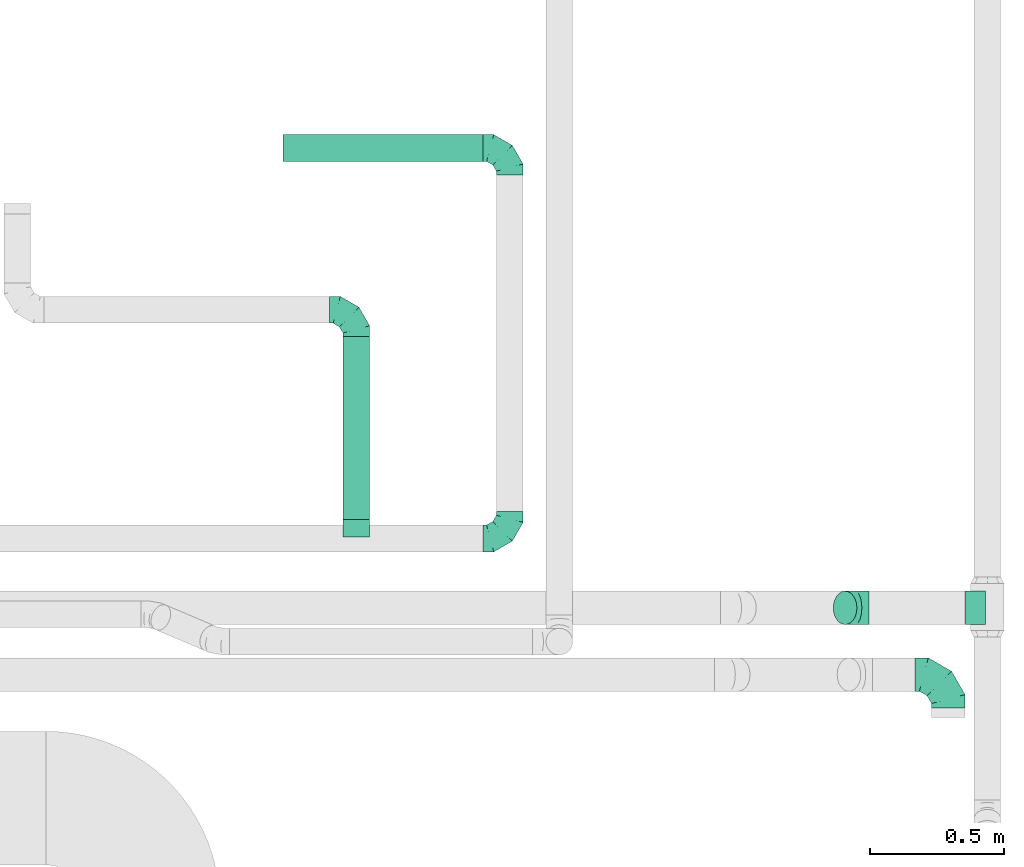
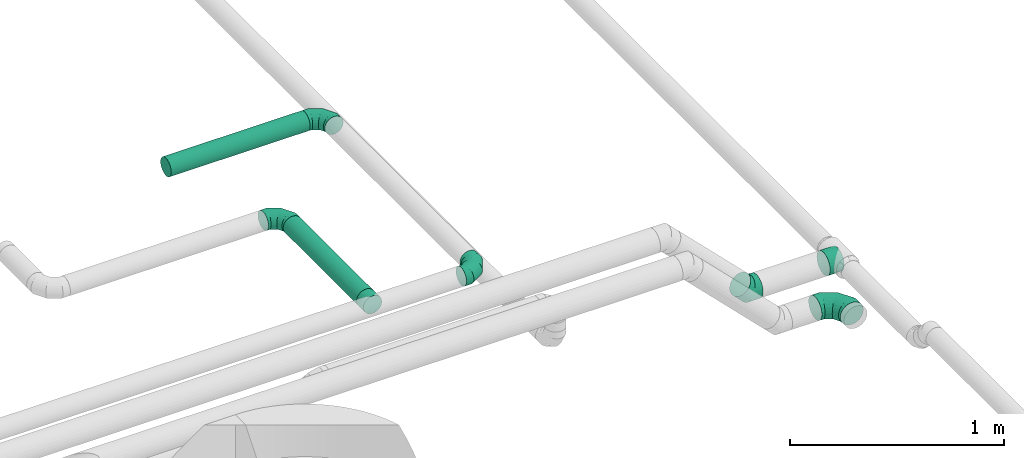
# One storey, part 51 of 60: 7 flow fittings, 2 flow segments.
"""IFC2X3 building model written with IfcOpenShell, lengths in millimetres."""

from ifc_helpers import new_model, entity, si_unit, converted_unit, derived_unit, direction, frame, origin, origin_2d_with_axis, place, context, subcontext, project, spatial, circle, extrude, faceted_brep, source, transform, mapped, material, type_object, type_shapes, element, save


model = new_model("IFC2X3")

# Units and contexts
model_context = context("Model", 3, precision=0.01, world=origin(), true_north=direction((6.12303176911189e-17, 1.0)))
body_context = subcontext(model_context, "Body", "Model", "MODEL_VIEW")
ifc_project = project(units=[si_unit("LENGTHUNIT", "METRE", prefix="MILLI"), si_unit("AREAUNIT", "SQUARE_METRE"), si_unit("VOLUMEUNIT", "CUBIC_METRE"), converted_unit("PLANEANGLEUNIT", "DEGREE", entity("IfcRatioMeasure", 0.0174532925199433), si_unit("PLANEANGLEUNIT", "RADIAN"), dimensions=[0, 0, 0, 0, 0, 0, 0]), si_unit("MASSUNIT", "GRAM", prefix="KILO"), derived_unit("MASSDENSITYUNIT", [(si_unit("MASSUNIT", "GRAM", prefix="KILO"), 1), (si_unit("LENGTHUNIT", "METRE"), -3)]), derived_unit("MOMENTOFINERTIAUNIT", [(si_unit("LENGTHUNIT", "METRE"), 4)]), si_unit("TIMEUNIT", "SECOND"), si_unit("FREQUENCYUNIT", "HERTZ"), si_unit("THERMODYNAMICTEMPERATUREUNIT", "DEGREE_CELSIUS"), derived_unit("THERMALTRANSMITTANCEUNIT", [(si_unit("MASSUNIT", "GRAM", prefix="KILO"), 1), (si_unit("THERMODYNAMICTEMPERATUREUNIT", "KELVIN"), -1), (si_unit("TIMEUNIT", "SECOND"), -3)]), derived_unit("VOLUMETRICFLOWRATEUNIT", [(si_unit("LENGTHUNIT", "METRE"), 3), (si_unit("TIMEUNIT", "SECOND"), -1)]), derived_unit("MASSFLOWRATEUNIT", [(si_unit("MASSUNIT", "GRAM", prefix="KILO"), 1), (si_unit("TIMEUNIT", "SECOND"), -1)]), derived_unit("ROTATIONALFREQUENCYUNIT", [(si_unit("TIMEUNIT", "SECOND"), -1)]), si_unit("ELECTRICCURRENTUNIT", "AMPERE"), si_unit("ELECTRICVOLTAGEUNIT", "VOLT"), si_unit("POWERUNIT", "WATT"), si_unit("FORCEUNIT", "NEWTON", prefix="KILO"), si_unit("ILLUMINANCEUNIT", "LUX"), si_unit("LUMINOUSFLUXUNIT", "LUMEN"), si_unit("LUMINOUSINTENSITYUNIT", "CANDELA"), derived_unit("USERDEFINED", [(si_unit("MASSUNIT", "GRAM", prefix="KILO"), -1), (si_unit("LENGTHUNIT", "METRE"), -2), (si_unit("TIMEUNIT", "SECOND"), 3), (si_unit("LUMINOUSFLUXUNIT", "LUMEN"), 1)]), derived_unit("LINEARVELOCITYUNIT", [(si_unit("LENGTHUNIT", "METRE"), 1), (si_unit("TIMEUNIT", "SECOND"), -1)]), si_unit("PRESSUREUNIT", "PASCAL"), derived_unit("USERDEFINED", [(si_unit("LENGTHUNIT", "METRE"), -2), (si_unit("MASSUNIT", "GRAM", prefix="KILO"), 1), (si_unit("TIMEUNIT", "SECOND"), -2)]), derived_unit("LINEARFORCEUNIT", [(si_unit("MASSUNIT", "GRAM", prefix="KILO"), 1), (si_unit("LENGTHUNIT", "METRE"), 1), (si_unit("TIMEUNIT", "SECOND"), -2), (si_unit("LENGTHUNIT", "METRE"), -1)]), derived_unit("PLANARFORCEUNIT", [(si_unit("MASSUNIT", "GRAM", prefix="KILO"), 1), (si_unit("LENGTHUNIT", "METRE"), 1), (si_unit("TIMEUNIT", "SECOND"), -2), (si_unit("LENGTHUNIT", "METRE"), -2)])], contexts=[model_context])

# Site, building, storey
site_placement = place(None, origin())
site = spatial("IfcSite", under=ifc_project, at=site_placement, CompositionType="ELEMENT")
building_placement = place(site_placement, origin())
building = spatial("IfcBuilding", under=site, at=building_placement, CompositionType="ELEMENT")
storey_placement = place(building_placement, frame((0.0, 0.0, 19800.0)))
storey = spatial("IfcBuildingStorey", under=building, at=storey_placement, CompositionType="ELEMENT", Elevation=19800.0)

# Flow segments
duct_segment_type = type_object("IfcDuctSegmentType", PredefinedType="NOTDEFINED")
flow_segment_1_placement = place(storey_placement, frame((69830.01, 10404.99, 3448.4)))
element("IfcFlowSegment", 1, at=flow_segment_1_placement, inside=storey, type_object=duct_segment_type, context=body_context, shape_type="SweptSolid", body=[
    extrude(circle(Radius=50.0, at=origin_2d_with_axis()), frame((51.6, 0.0, 51.6), z_axis=(0.0, 1.0, 0.0), x_axis=(-1.0, 0.0, 0.0)), (0.0, 0.0, 1.0), 685.000000000022),
])
flow_segment_2_placement = place(storey_placement, frame((69606.61, 11743.4, 3448.4)))
element("IfcFlowSegment", 2, at=flow_segment_2_placement, inside=storey, type_object=duct_segment_type, context=body_context, shape_type="SweptSolid", body=[
    extrude(circle(Radius=50.0, at=origin_2d_with_axis()), frame((0.0, 51.6, 51.6), z_axis=(1.0, 0.0, 0.0), x_axis=(0.0, 1.0, 0.0)), (0.0, 0.0, 1.0), 748.749999999973),
])

# Flow fittings
ifc_material = material()
duct_fitting_type_1 = type_object("IfcDuctFittingType", PredefinedType="NOTDEFINED", material=ifc_material)
shared_shape_1 = source(origin(), body_context, "Body", "Brep", [
    faceted_brep([(-100.0, 0.0, -50.0), (-100.0, -12.94, -48.3), (-100.0, -25.0, -43.3), (-100.0, -35.36, -35.36), (-100.0, -43.3, -25.0), (-100.0, -48.3, -12.94), (-100.0, -50.0, 0.0), (-100.0, -48.3, 12.94), (-100.0, -43.3, 25.0), (-100.0, -35.36, 35.36), (-100.0, -25.0, 43.3), (-100.0, -12.94, 48.3), (-100.0, 0.0, 50.0), (-100.0, 12.94, 48.3), (-100.0, 25.0, 43.3), (-100.0, 35.36, 35.36), (-100.0, 43.3, 25.0), (-100.0, 48.3, 12.94), (-100.0, 50.0, 0.0), (-100.0, 48.3, -12.94), (-100.0, 43.3, -25.0), (-100.0, 35.36, -35.36), (-100.0, 25.0, -43.3), (-100.0, 12.94, -48.3), (-76.67, 12.94, 48.3), (-79.9, 25.0, 43.3), (-73.21, 0.0, 50.0), (-82.68, 35.36, 35.36), (-86.15, 48.3, 12.94), (-86.6, 50.0, 0.0), (-84.81, 43.3, 25.0), (-84.81, 43.3, -25.0), (-82.68, 35.36, -35.36), (-86.15, 48.3, -12.94), (-76.67, 12.94, -48.3), (-73.21, 0.0, -50.0), (-79.9, 25.0, -43.3), (-69.74, -12.94, -48.3), (-66.51, -25.0, -43.3), (-63.73, -35.36, -35.36), (-61.6, -43.3, -25.0), (-60.26, -48.3, -12.94), (-59.81, -50.0, 0.0), (-60.26, -48.3, 12.94), (-61.6, -43.3, 25.0), (-63.73, -35.36, 35.36), (-66.51, -25.0, 43.3), (-69.74, -12.94, 48.3), (-36.27, 36.27, 48.3), (-45.1, 45.1, 43.3), (-26.79, 26.79, 50.0), (-52.68, 52.68, 35.36), (-58.49, 58.49, 25.0), (-62.15, 62.15, 12.94), (-63.4, 63.4, 0.0), (-62.15, 62.15, -12.94), (-58.49, 58.49, -25.0), (-52.68, 52.68, -35.36), (-36.27, 36.27, -48.3), (-26.79, 26.79, -50.0), (-45.1, 45.1, -43.3), (-17.32, 17.32, -48.3), (-8.49, 8.49, -43.3), (-0.91, 0.91, -35.36), (4.9, -4.9, -25.0), (8.56, -8.56, -12.94), (9.81, -9.81, 0.0), (8.56, -8.56, 12.94), (4.9, -4.9, 25.0), (-0.91, 0.91, 35.36), (-8.49, 8.49, 43.3), (-17.32, 17.32, 48.3), (-12.94, 76.67, 48.3), (-25.0, 79.9, 43.3), (0.0, 73.21, 50.0), (-35.36, 82.68, 35.36), (-43.3, 84.81, 25.0), (-48.3, 86.15, 12.94), (-50.0, 86.6, 0.0), (-48.3, 86.15, -12.94), (-43.3, 84.81, -25.0), (-35.36, 82.68, -35.36), (-12.94, 76.67, -48.3), (0.0, 73.21, -50.0), (-25.0, 79.9, -43.3), (12.94, 69.74, -48.3), (25.0, 66.51, -43.3), (35.36, 63.73, -35.36), (43.3, 61.6, -25.0), (48.3, 60.26, -12.94), (50.0, 59.81, 0.0), (48.3, 60.26, 12.94), (43.3, 61.6, 25.0), (35.36, 63.73, 35.36), (25.0, 66.51, 43.3), (12.94, 69.74, 48.3), (-12.94, 100.0, -48.3), (-25.0, 100.0, -43.3), (-35.36, 100.0, -35.36), (-43.3, 100.0, -25.0), (-48.3, 100.0, -12.94), (-50.0, 100.0, 0.0), (-48.3, 100.0, 12.94), (-43.3, 100.0, 25.0), (-35.36, 100.0, 35.36), (-25.0, 100.0, 43.3), (-12.94, 100.0, 48.3), (0.0, 100.0, 50.0), (12.94, 100.0, 48.3), (25.0, 100.0, 43.3), (35.36, 100.0, 35.36), (43.3, 100.0, 25.0), (48.3, 100.0, 12.94), (50.0, 100.0, 0.0), (48.3, 100.0, -12.94), (43.3, 100.0, -25.0), (35.36, 100.0, -35.36), (25.0, 100.0, -43.3), (12.94, 100.0, -48.3), (0.0, 100.0, -50.0)], [[[0, 1, 2, 3, 4, 5, 6, 7, 8, 9, 10, 11, 12, 13, 14, 15, 16, 17, 18, 19, 20, 21, 22, 23]], [[24, 25, 14, 13]], [[26, 24, 13, 12]], [[14, 25, 27, 15]], [[28, 29, 18, 17]], [[30, 28, 17, 16]], [[15, 27, 30, 16]], [[20, 31, 32, 21]], [[33, 31, 20, 19]], [[18, 29, 33, 19]], [[34, 35, 0, 23]], [[36, 34, 23, 22]], [[32, 36, 22, 21]], [[2, 1, 37, 38]], [[3, 2, 38, 39]], [[0, 35, 37, 1]], [[5, 4, 40, 41]], [[6, 5, 41, 42]], [[3, 39, 40, 4]], [[6, 42, 43, 7]], [[7, 43, 44, 8]], [[8, 44, 45, 9]], [[10, 46, 47, 11]], [[11, 47, 26, 12]], [[10, 9, 45, 46]], [[48, 49, 25, 24]], [[50, 48, 24, 26]], [[27, 25, 49, 51]], [[52, 53, 28, 30]], [[51, 52, 30, 27]], [[29, 28, 53, 54]], [[55, 56, 31, 33]], [[54, 55, 33, 29]], [[57, 32, 31, 56]], [[58, 59, 35, 34]], [[60, 58, 34, 36]], [[57, 60, 36, 32]], [[37, 35, 59, 61]], [[38, 37, 61, 62]], [[39, 38, 62, 63]], [[41, 40, 64, 65]], [[42, 41, 65, 66]], [[63, 64, 40, 39]], [[43, 42, 66, 67]], [[44, 43, 67, 68]], [[68, 69, 45, 44]], [[46, 45, 69, 70]], [[47, 46, 70, 71]], [[26, 47, 71, 50]], [[72, 73, 49, 48]], [[74, 72, 48, 50]], [[51, 49, 73, 75]], [[76, 77, 53, 52]], [[75, 76, 52, 51]], [[54, 53, 77, 78]], [[79, 80, 56, 55]], [[78, 79, 55, 54]], [[81, 57, 56, 80]], [[82, 83, 59, 58]], [[84, 82, 58, 60]], [[81, 84, 60, 57]], [[61, 59, 83, 85]], [[62, 61, 85, 86]], [[63, 62, 86, 87]], [[65, 64, 88, 89]], [[66, 65, 89, 90]], [[87, 88, 64, 63]], [[67, 66, 90, 91]], [[68, 67, 91, 92]], [[92, 93, 69, 68]], [[70, 69, 93, 94]], [[71, 70, 94, 95]], [[50, 71, 95, 74]], [[96, 97, 98, 99, 100, 101, 102, 103, 104, 105, 106, 107, 108, 109, 110, 111, 112, 113, 114, 115, 116, 117, 118, 119]], [[72, 74, 107, 106]], [[73, 72, 106, 105]], [[75, 73, 105, 104]], [[77, 76, 103, 102]], [[78, 77, 102, 101]], [[75, 104, 103, 76]], [[78, 101, 100, 79]], [[79, 100, 99, 80]], [[80, 99, 98, 81]], [[96, 119, 83, 82]], [[97, 96, 82, 84]], [[84, 81, 98, 97]], [[83, 119, 118, 85]], [[85, 118, 117, 86]], [[86, 117, 116, 87]], [[88, 115, 114, 89]], [[89, 114, 113, 90]], [[87, 116, 115, 88]], [[91, 90, 113, 112]], [[92, 91, 112, 111]], [[93, 92, 111, 110]], [[95, 94, 109, 108]], [[74, 95, 108, 107]], [[110, 109, 94, 93]]]),
])
type_shapes(duct_fitting_type_1, [shared_shape_1])
flow_fitting_1_placement = place(storey_placement, frame((70455.36, 10334.99, 3500.0)))
element("IfcFlowFitting", 3, at=flow_fitting_1_placement, inside=storey, type_object=duct_fitting_type_1, material=ifc_material, context=body_context, shape_type="MappedRepresentation", body=[
    mapped(shared_shape_1, transform((0.0, 0.0, 0.0), scale=1.0)),
])
for number, where, z_axis, x_axis in (
    (4, (70455.36, 11794.99, 3500.0), (0.0, 0.0, 1.0), (0.0, 1.0, 0.0)),
    (5, (69881.61, 11189.99, 3500.0), (0.0, 0.0, 1.0), (0.0, 1.0, 0.0)),
):
    element("IfcFlowFitting", number, at=place(storey_placement, frame(where, z_axis=z_axis, x_axis=x_axis)), inside=storey, type_object=duct_fitting_type_1, material=ifc_material, context=body_context, shape_type="MappedRepresentation", body=[
        mapped(shared_shape_1, transform((0.0, 0.0, 0.0), scale=1.0)),
    ])
duct_fitting_type_2 = type_object("IfcDuctFittingType", PredefinedType="NOTDEFINED", material=ifc_material)
shared_shape_2 = source(origin(), body_context, "Body", "Brep", [
    faceted_brep([(-125.0, 0.0, -62.5), (-125.0, -16.18, -60.37), (-125.0, -31.25, -54.13), (-125.0, -44.19, -44.19), (-125.0, -54.13, -31.25), (-125.0, -60.37, -16.18), (-125.0, -62.5, 0.0), (-125.0, -60.37, 16.18), (-125.0, -54.13, 31.25), (-125.0, -44.19, 44.19), (-125.0, -31.25, 54.13), (-125.0, -16.18, 60.37), (-125.0, 0.0, 62.5), (-125.0, 16.18, 60.37), (-125.0, 31.25, 54.13), (-125.0, 44.19, 44.19), (-125.0, 54.13, 31.25), (-125.0, 60.37, 16.18), (-125.0, 62.5, 0.0), (-125.0, 60.37, -16.18), (-125.0, 54.13, -31.25), (-125.0, 44.19, -44.19), (-125.0, 31.25, -54.13), (-125.0, 16.18, -60.37), (-95.84, 16.18, 60.37), (-99.88, 31.25, 54.13), (-91.51, 0.0, 62.5), (-103.35, 44.19, 44.19), (-107.68, 60.37, 16.18), (-108.25, 62.5, 0.0), (-106.01, 54.13, 31.25), (-106.01, 54.13, -31.25), (-103.35, 44.19, -44.19), (-107.68, 60.37, -16.18), (-95.84, 16.18, -60.37), (-91.51, 0.0, -62.5), (-99.88, 31.25, -54.13), (-87.17, -16.18, -60.37), (-83.13, -31.25, -54.13), (-79.66, -44.19, -44.19), (-77.0, -54.13, -31.25), (-75.33, -60.37, -16.18), (-74.76, -62.5, 0.0), (-75.33, -60.37, 16.18), (-77.0, -54.13, 31.25), (-79.66, -44.19, 44.19), (-83.13, -31.25, 54.13), (-87.17, -16.18, 60.37), (-45.34, 45.34, 60.37), (-56.37, 56.37, 54.13), (-33.49, 33.49, 62.5), (-65.85, 65.85, 44.19), (-73.12, 73.12, 31.25), (-77.69, 77.69, 16.18), (-79.25, 79.25, 0.0), (-77.69, 77.69, -16.18), (-73.12, 73.12, -31.25), (-65.85, 65.85, -44.19), (-45.34, 45.34, -60.37), (-33.49, 33.49, -62.5), (-56.37, 56.37, -54.13), (-21.65, 21.65, -60.37), (-10.62, 10.62, -54.13), (-1.14, 1.14, -44.19), (6.13, -6.13, -31.25), (10.7, -10.7, -16.18), (12.26, -12.26, 0.0), (10.7, -10.7, 16.18), (6.13, -6.13, 31.25), (-1.14, 1.14, 44.19), (-10.62, 10.62, 54.13), (-21.65, 21.65, 60.37), (-16.18, 95.84, 60.37), (-31.25, 99.88, 54.13), (0.0, 91.51, 62.5), (-44.19, 103.35, 44.19), (-54.13, 106.01, 31.25), (-60.37, 107.68, 16.18), (-62.5, 108.25, 0.0), (-60.37, 107.68, -16.18), (-54.13, 106.01, -31.25), (-44.19, 103.35, -44.19), (-16.18, 95.84, -60.37), (0.0, 91.51, -62.5), (-31.25, 99.88, -54.13), (16.18, 87.17, -60.37), (31.25, 83.13, -54.13), (44.19, 79.66, -44.19), (54.13, 77.0, -31.25), (60.37, 75.33, -16.18), (62.5, 74.76, 0.0), (60.37, 75.33, 16.18), (54.13, 77.0, 31.25), (44.19, 79.66, 44.19), (31.25, 83.13, 54.13), (16.18, 87.17, 60.37), (-16.18, 125.0, -60.37), (-31.25, 125.0, -54.13), (-44.19, 125.0, -44.19), (-54.13, 125.0, -31.25), (-60.37, 125.0, -16.18), (-62.5, 125.0, 0.0), (-60.37, 125.0, 16.18), (-54.13, 125.0, 31.25), (-44.19, 125.0, 44.19), (-31.25, 125.0, 54.13), (-16.18, 125.0, 60.37), (0.0, 125.0, 62.5), (16.18, 125.0, 60.37), (31.25, 125.0, 54.13), (44.19, 125.0, 44.19), (54.13, 125.0, 31.25), (60.37, 125.0, 16.18), (62.5, 125.0, 0.0), (60.37, 125.0, -16.18), (54.13, 125.0, -31.25), (44.19, 125.0, -44.19), (31.25, 125.0, -54.13), (16.18, 125.0, -60.37), (0.0, 125.0, -62.5)], [[[0, 1, 2, 3, 4, 5, 6, 7, 8, 9, 10, 11, 12, 13, 14, 15, 16, 17, 18, 19, 20, 21, 22, 23]], [[24, 25, 14, 13]], [[26, 24, 13, 12]], [[14, 25, 27, 15]], [[28, 29, 18, 17]], [[30, 28, 17, 16]], [[15, 27, 30, 16]], [[20, 31, 32, 21]], [[33, 31, 20, 19]], [[18, 29, 33, 19]], [[34, 35, 0, 23]], [[36, 34, 23, 22]], [[21, 32, 36, 22]], [[1, 0, 35, 37]], [[2, 1, 37, 38]], [[38, 39, 3, 2]], [[5, 4, 40, 41]], [[6, 5, 41, 42]], [[39, 40, 4, 3]], [[6, 42, 43, 7]], [[7, 43, 44, 8]], [[45, 9, 8, 44]], [[9, 45, 46, 10]], [[10, 46, 47, 11]], [[26, 12, 11, 47]], [[48, 49, 25, 24]], [[50, 48, 24, 26]], [[27, 25, 49, 51]], [[52, 53, 28, 30]], [[51, 52, 30, 27]], [[29, 28, 53, 54]], [[55, 56, 31, 33]], [[54, 55, 33, 29]], [[57, 32, 31, 56]], [[58, 59, 35, 34]], [[60, 58, 34, 36]], [[57, 60, 36, 32]], [[37, 35, 59, 61]], [[38, 37, 61, 62]], [[39, 38, 62, 63]], [[41, 40, 64, 65]], [[42, 41, 65, 66]], [[63, 64, 40, 39]], [[43, 42, 66, 67]], [[44, 43, 67, 68]], [[68, 69, 45, 44]], [[46, 45, 69, 70]], [[47, 46, 70, 71]], [[26, 47, 71, 50]], [[72, 73, 49, 48]], [[74, 72, 48, 50]], [[51, 49, 73, 75]], [[76, 77, 53, 52]], [[75, 76, 52, 51]], [[54, 53, 77, 78]], [[79, 80, 56, 55]], [[78, 79, 55, 54]], [[81, 57, 56, 80]], [[82, 83, 59, 58]], [[84, 82, 58, 60]], [[81, 84, 60, 57]], [[61, 59, 83, 85]], [[62, 61, 85, 86]], [[63, 62, 86, 87]], [[65, 64, 88, 89]], [[66, 65, 89, 90]], [[87, 88, 64, 63]], [[67, 66, 90, 91]], [[68, 67, 91, 92]], [[92, 93, 69, 68]], [[70, 69, 93, 94]], [[71, 70, 94, 95]], [[50, 71, 95, 74]], [[96, 97, 98, 99, 100, 101, 102, 103, 104, 105, 106, 107, 108, 109, 110, 111, 112, 113, 114, 115, 116, 117, 118, 119]], [[72, 74, 107, 106]], [[73, 72, 106, 105]], [[75, 73, 105, 104]], [[77, 76, 103, 102]], [[78, 77, 102, 101]], [[75, 104, 103, 76]], [[78, 101, 100, 79]], [[79, 100, 99, 80]], [[80, 99, 98, 81]], [[96, 119, 83, 82]], [[97, 96, 82, 84]], [[84, 81, 98, 97]], [[83, 119, 118, 85]], [[85, 118, 117, 86]], [[116, 87, 86, 117]], [[88, 115, 114, 89]], [[89, 114, 113, 90]], [[115, 88, 87, 116]], [[91, 90, 113, 112]], [[92, 91, 112, 111]], [[111, 110, 93, 92]], [[95, 94, 109, 108]], [[74, 95, 108, 107]], [[110, 109, 94, 93]]]),
])
type_shapes(duct_fitting_type_2, [shared_shape_2])
flow_fitting_2_placement = place(storey_placement, frame((72095.38, 9826.0, 3062.5), z_axis=(0.0, 0.0, 1.0), x_axis=(0.0, 1.0, 0.0)))
element("IfcFlowFitting", 6, at=flow_fitting_2_placement, inside=storey, type_object=duct_fitting_type_2, material=ifc_material, context=body_context, shape_type="MappedRepresentation", body=[
    mapped(shared_shape_2, transform((0.0, 0.0, 0.0), scale=1.0)),
])
duct_fitting_type_3 = type_object("IfcDuctFittingType", PredefinedType="NOTDEFINED", material=ifc_material)
shared_shape_3 = source(origin(), body_context, "Body", "Brep", [
    faceted_brep([(-51.78, 0.0, -62.5), (-51.78, -16.18, -60.37), (-51.78, -31.25, -54.13), (-51.78, -44.19, -44.19), (-51.78, -54.13, -31.25), (-51.78, -60.37, -16.18), (-51.78, -62.5, 0.0), (-51.78, -60.37, 16.18), (-51.78, -54.13, 31.25), (-51.78, -44.19, 44.19), (-51.78, -31.25, 54.13), (-51.78, -16.18, 60.37), (-51.78, 0.0, 62.5), (-51.78, 16.18, 60.37), (-51.78, 31.25, 54.13), (-51.78, 44.19, 44.19), (-51.78, 54.13, 31.25), (-51.78, 60.37, 16.18), (-51.78, 62.5, 0.0), (-51.78, 60.37, -16.18), (-51.78, 54.13, -31.25), (-51.78, 44.19, -44.19), (-51.78, 31.25, -54.13), (-51.78, 16.18, -60.37), (-6.7, 16.18, 60.37), (-12.94, 31.25, 54.13), (0.0, 0.0, 62.5), (-18.31, 44.19, 44.19), (-22.42, 54.13, 31.25), (-25.01, 60.37, 16.18), (-25.89, 62.5, 0.0), (-25.01, 60.37, -16.18), (-22.42, 54.13, -31.25), (-18.31, 44.19, -44.19), (-6.7, 16.18, -60.37), (0.0, 0.0, -62.5), (-12.94, 31.25, -54.13), (6.7, -16.18, -60.37), (12.94, -31.25, -54.13), (18.31, -44.19, -44.19), (22.42, -54.13, -31.25), (25.01, -60.37, -16.18), (25.89, -62.5, 0.0), (25.01, -60.37, 16.18), (22.42, -54.13, 31.25), (18.31, -44.19, 44.19), (12.94, -31.25, 54.13), (6.7, -16.18, 60.37), (25.17, 48.05, 60.37), (14.51, 58.71, 54.13), (36.61, 36.61, 62.5), (5.36, 67.86, 44.19), (-1.66, 74.88, 31.25), (-6.08, 79.3, 16.18), (-7.58, 80.81, 0.0), (-6.08, 79.3, -16.18), (-1.66, 74.88, -31.25), (5.36, 67.86, -44.19), (14.51, 58.71, -54.13), (25.17, 48.05, -60.37), (36.61, 36.61, -62.5), (48.05, 25.17, -60.37), (58.71, 14.51, -54.13), (67.86, 5.36, -44.19), (74.88, -1.66, -31.25), (79.3, -6.08, -16.18), (80.81, -7.58, 0.0), (79.3, -6.08, 16.18), (74.88, -1.66, 31.25), (67.86, 5.36, 44.19), (58.71, 14.51, 54.13), (48.05, 25.17, 60.37)], [[[0, 1, 2, 3, 4, 5, 6, 7, 8, 9, 10, 11, 12, 13, 14, 15, 16, 17, 18, 19, 20, 21, 22, 23]], [[24, 25, 14, 13]], [[26, 24, 13, 12]], [[27, 15, 14, 25]], [[28, 29, 17, 16]], [[28, 16, 15, 27]], [[30, 18, 17, 29]], [[31, 32, 20, 19]], [[30, 31, 19, 18]], [[21, 20, 32, 33]], [[34, 35, 0, 23]], [[36, 34, 23, 22]], [[33, 36, 22, 21]], [[1, 0, 35, 37]], [[2, 1, 37, 38]], [[38, 39, 3, 2]], [[5, 4, 40, 41]], [[6, 5, 41, 42]], [[39, 40, 4, 3]], [[6, 42, 43, 7]], [[7, 43, 44, 8]], [[8, 44, 45, 9]], [[9, 45, 46, 10]], [[10, 46, 47, 11]], [[26, 12, 11, 47]], [[48, 49, 25, 24]], [[50, 48, 24, 26]], [[27, 25, 49, 51]], [[29, 28, 52, 53]], [[30, 29, 53, 54]], [[51, 52, 28, 27]], [[30, 54, 55, 31]], [[31, 55, 56, 32]], [[57, 33, 32, 56]], [[36, 58, 59, 34]], [[34, 59, 60, 35]], [[58, 36, 33, 57]], [[35, 60, 61, 37]], [[37, 61, 62, 38]], [[63, 39, 38, 62]], [[40, 64, 65, 41]], [[41, 65, 66, 42]], [[64, 40, 39, 63]], [[43, 42, 66, 67]], [[44, 43, 67, 68]], [[68, 69, 45, 44]], [[47, 46, 70, 71]], [[26, 47, 71, 50]], [[69, 70, 46, 45]], [[59, 58, 57, 56, 55, 54, 53, 52, 51, 49, 48, 50, 71, 70, 69, 68, 67, 66, 65, 64, 63, 62, 61, 60]]]),
])
type_shapes(duct_fitting_type_3, [shared_shape_3])
flow_fitting_3_placement = place(storey_placement, frame((71746.06, 10075.43, 3100.03), z_axis=(0.0, -1.0, 0.0), x_axis=(0.707106781186515, 0.0, -0.70710678118658)))
element("IfcFlowFitting", 7, at=flow_fitting_3_placement, inside=storey, type_object=duct_fitting_type_3, material=ifc_material, context=body_context, shape_type="MappedRepresentation", body=[
    mapped(shared_shape_3, transform((0.0, 0.0, 0.0), scale=1.0)),
])
duct_fitting_type_4 = type_object("IfcDuctFittingType", PredefinedType="NOTDEFINED", material=ifc_material)
shared_shape_4 = source(origin(), body_context, "Body", "Brep", [
    faceted_brep([(20.0, 12.94, -48.3), (20.0, 25.0, -43.3), (20.0, 35.36, -35.36), (20.0, 43.3, -25.0), (20.0, 48.3, -12.94), (20.0, 50.0, 0.0), (20.0, 48.3, 12.94), (20.0, 43.3, 25.0), (20.0, 35.36, 35.36), (20.0, 25.0, 43.3), (20.0, 12.94, 48.3), (20.0, 0.0, 50.0), (20.0, -12.94, 48.3), (20.0, -25.0, 43.3), (20.0, -35.36, 35.36), (20.0, -43.3, 25.0), (20.0, -48.3, 12.94), (20.0, -50.0, 0.0), (20.0, -48.3, -12.94), (20.0, -43.3, -25.0), (20.0, -35.36, -35.36), (20.0, -25.0, -43.3), (20.0, -12.94, -48.3), (20.0, 0.0, -50.0), (0.0, 0.0, 50.0), (0.0, 12.94, 48.3), (-43.9, 12.94, 48.3), (-43.9, 0.0, 50.0), (0.0, 25.0, 43.3), (-43.9, 25.0, 43.3), (0.0, 35.36, 35.36), (-43.9, 35.36, 35.36), (0.0, 43.3, 25.0), (0.0, 48.3, 12.94), (-43.9, 48.3, 12.94), (-43.9, 43.3, 25.0), (0.0, 50.0, 0.0), (-43.9, 50.0, 0.0), (0.0, 48.3, -12.94), (-43.9, 48.3, -12.94), (0.0, 43.3, -25.0), (-43.9, 43.3, -25.0), (0.0, 35.36, -35.36), (-43.9, 35.36, -35.36), (0.0, 25.0, -43.3), (0.0, 12.94, -48.3), (-43.9, 12.94, -48.3), (-43.9, 25.0, -43.3), (0.0, 0.0, -50.0), (-43.9, 0.0, -50.0), (0.0, -12.94, -48.3), (-43.9, -12.94, -48.3), (0.0, -25.0, -43.3), (-43.9, -25.0, -43.3), (0.0, -35.36, -35.36), (-43.9, -35.36, -35.36), (0.0, -43.3, -25.0), (0.0, -48.3, -12.94), (-43.9, -48.3, -12.94), (-43.9, -43.3, -25.0), (0.0, -50.0, 0.0), (-43.9, -50.0, 0.0), (0.0, -48.3, 12.94), (-43.9, -48.3, 12.94), (0.0, -43.3, 25.0), (-43.9, -43.3, 25.0), (0.0, -35.36, 35.36), (-43.9, -35.36, 35.36), (0.0, -25.0, 43.3), (0.0, -12.94, 48.3), (-43.9, -12.94, 48.3), (-43.9, -25.0, 43.3)], [[[0, 1, 2, 3, 4, 5, 6, 7, 8, 9, 10, 11, 12, 13, 14, 15, 16, 17, 18, 19, 20, 21, 22, 23]], [[24, 11, 10, 25, 26, 27]], [[25, 10, 9, 28, 29, 26]], [[28, 9, 8, 30, 31, 29]], [[32, 7, 6, 33, 34, 35]], [[33, 6, 5, 36, 37, 34]], [[30, 8, 7, 32, 35, 31]], [[36, 5, 4, 38, 39, 37]], [[38, 4, 3, 40, 41, 39]], [[40, 3, 2, 42, 43, 41]], [[44, 1, 0, 45, 46, 47]], [[45, 0, 23, 48, 49, 46]], [[42, 2, 1, 44, 47, 43]], [[48, 23, 22, 50, 51, 49]], [[50, 22, 21, 52, 53, 51]], [[52, 21, 20, 54, 55, 53]], [[56, 19, 18, 57, 58, 59]], [[57, 18, 17, 60, 61, 58]], [[54, 20, 19, 56, 59, 55]], [[60, 17, 16, 62, 63, 61]], [[62, 16, 15, 64, 65, 63]], [[64, 15, 14, 66, 67, 65]], [[68, 13, 12, 69, 70, 71]], [[69, 12, 11, 24, 27, 70]], [[66, 14, 13, 68, 71, 67]], [[49, 51, 53, 55, 59, 58, 61, 63, 65, 67, 71, 70, 27, 26, 29, 31, 35, 34, 37, 39, 41, 43, 47, 46]]]),
])
type_shapes(duct_fitting_type_4, [shared_shape_4])
flow_fitting_4_placement = place(storey_placement, frame((69881.61, 10384.99, 3500.0), z_axis=(0.0, 0.0, -1.0), x_axis=(0.0, 1.0, 0.0)))
element("IfcFlowFitting", 8, at=flow_fitting_4_placement, inside=storey, type_object=duct_fitting_type_4, material=ifc_material, context=body_context, shape_type="MappedRepresentation", body=[
    mapped(shared_shape_4, transform((0.0, 0.0, 0.0), scale=1.0)),
])
duct_fitting_type_5 = type_object("IfcDuctFittingType", PredefinedType="NOTDEFINED", material=ifc_material)
shared_shape_5 = source(origin(), body_context, "Body", "Brep", [
    faceted_brep([(20.0, 0.0, -62.5), (20.0, 16.18, -60.37), (20.0, 31.25, -54.13), (20.0, 44.19, -44.19), (20.0, 54.13, -31.25), (20.0, 60.37, -16.18), (20.0, 62.5, 0.0), (20.0, 60.37, 16.18), (20.0, 54.13, 31.25), (20.0, 44.19, 44.19), (20.0, 31.25, 54.13), (20.0, 16.18, 60.37), (20.0, 0.0, 62.5), (20.0, -16.18, 60.37), (20.0, -31.25, 54.13), (20.0, -44.19, 44.19), (20.0, -54.13, 31.25), (20.0, -60.37, 16.18), (20.0, -62.5, 0.0), (20.0, -60.37, -16.18), (20.0, -54.13, -31.25), (20.0, -44.19, -44.19), (20.0, -31.25, -54.13), (20.0, -16.18, -60.37), (0.0, 0.0, 62.5), (-56.4, 0.0, 62.5), (-56.4, -16.18, 60.37), (0.0, -16.18, 60.37), (-56.4, -31.25, 54.13), (0.0, -31.25, 54.13), (0.0, -44.19, 44.19), (-56.4, -44.19, 44.19), (0.0, -54.13, 31.25), (-56.4, -54.13, 31.25), (-56.4, -60.37, 16.18), (0.0, -60.37, 16.18), (-56.4, -62.5, 0.0), (0.0, -62.5, 0.0), (-56.4, -60.37, -16.18), (0.0, -60.37, -16.18), (-56.4, -54.13, -31.25), (0.0, -54.13, -31.25), (0.0, -44.19, -44.19), (-56.4, -44.19, -44.19), (0.0, -31.25, -54.13), (-56.4, -31.25, -54.13), (-56.4, -16.18, -60.37), (0.0, -16.18, -60.37), (-56.4, 0.0, -62.5), (0.0, 0.0, -62.5), (-56.4, 16.18, -60.37), (0.0, 16.18, -60.37), (-56.4, 31.25, -54.13), (0.0, 31.25, -54.13), (0.0, 44.19, -44.19), (-56.4, 44.19, -44.19), (0.0, 54.13, -31.25), (-56.4, 54.13, -31.25), (-56.4, 60.37, -16.18), (0.0, 60.37, -16.18), (-56.4, 62.5, 0.0), (0.0, 62.5, 0.0), (-56.4, 60.37, 16.18), (0.0, 60.37, 16.18), (-56.4, 54.13, 31.25), (0.0, 54.13, 31.25), (0.0, 44.19, 44.19), (-56.4, 44.19, 44.19), (0.0, 31.25, 54.13), (-56.4, 31.25, 54.13), (-56.4, 16.18, 60.37), (0.0, 16.18, 60.37)], [[[0, 1, 2, 3, 4, 5, 6, 7, 8, 9, 10, 11, 12, 13, 14, 15, 16, 17, 18, 19, 20, 21, 22, 23]], [[13, 12, 24, 25, 26, 27]], [[14, 13, 27, 26, 28, 29]], [[30, 15, 14, 29, 28, 31]], [[17, 16, 32, 33, 34, 35]], [[18, 17, 35, 34, 36, 37]], [[32, 16, 15, 30, 31, 33]], [[19, 18, 37, 36, 38, 39]], [[20, 19, 39, 38, 40, 41]], [[42, 21, 20, 41, 40, 43]], [[23, 22, 44, 45, 46, 47]], [[0, 23, 47, 46, 48, 49]], [[44, 22, 21, 42, 43, 45]], [[1, 0, 49, 48, 50, 51]], [[2, 1, 51, 50, 52, 53]], [[54, 3, 2, 53, 52, 55]], [[5, 4, 56, 57, 58, 59]], [[6, 5, 59, 58, 60, 61]], [[56, 4, 3, 54, 55, 57]], [[7, 6, 61, 60, 62, 63]], [[8, 7, 63, 62, 64, 65]], [[66, 9, 8, 65, 64, 67]], [[11, 10, 68, 69, 70, 71]], [[12, 11, 71, 70, 25, 24]], [[68, 10, 9, 66, 67, 69]], [[46, 45, 43, 40, 38, 36, 34, 33, 31, 28, 26, 25, 70, 69, 67, 64, 62, 60, 58, 57, 55, 52, 50, 48]]]),
])
type_shapes(duct_fitting_type_5, [shared_shape_5])
flow_fitting_5_placement = place(storey_placement, frame((72178.56, 10075.73, 3099.92), z_axis=(0.0, 0.0, -1.0), x_axis=(-1.0, 0.0, 0.0)))
element("IfcFlowFitting", 9, at=flow_fitting_5_placement, inside=storey, type_object=duct_fitting_type_5, material=ifc_material, context=body_context, shape_type="MappedRepresentation", body=[
    mapped(shared_shape_5, transform((0.0, 0.0, 0.0), scale=1.0)),
])

save(model, "model.ifc")
